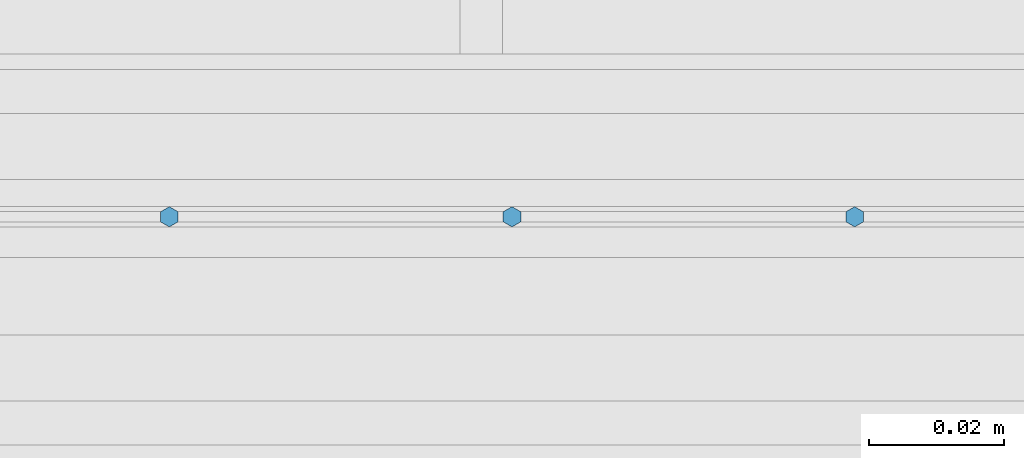
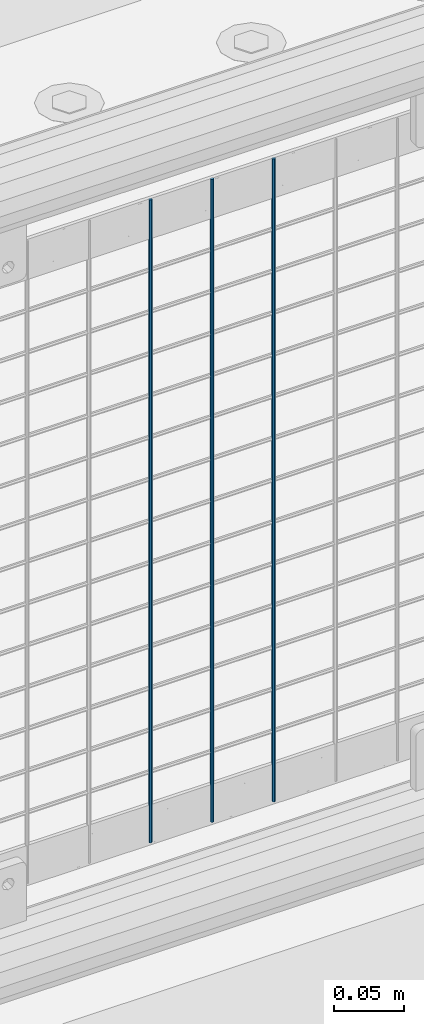
# One storey, part 87 of 242: 3 columns.
"""IFC2X3 building model written with IfcOpenShell, lengths in millimetres."""

from ifc_helpers import new_model, si_unit, frame, origin_with_axes, place, context, subcontext, project, spatial, faceted_brep, material, type_object, element, save


model = new_model("IFC2X3")

# Units and contexts
model_context = context("Model", 3, precision=1e-05, world=origin_with_axes())
body_context = subcontext(model_context, "Body", "Model", "MODEL_VIEW")
ifc_project = project(units=[si_unit("LENGTHUNIT", "METRE", prefix="MILLI"), si_unit("AREAUNIT", "SQUARE_METRE"), si_unit("VOLUMEUNIT", "CUBIC_METRE"), si_unit("MASSUNIT", "GRAM", prefix="KILO"), si_unit("TIMEUNIT", "SECOND"), si_unit("PLANEANGLEUNIT", "RADIAN"), si_unit("SOLIDANGLEUNIT", "STERADIAN"), si_unit("THERMODYNAMICTEMPERATUREUNIT", "DEGREE_CELSIUS"), si_unit("LUMINOUSINTENSITYUNIT", "LUMEN")], contexts=[model_context])

# Site, building, storey
site_placement = place(None, origin_with_axes())
site = spatial("IfcSite", under=ifc_project, at=site_placement, CompositionType="ELEMENT")
building_placement = place(site_placement, origin_with_axes())
building = spatial("IfcBuilding", under=site, at=building_placement, Name="Standard", CompositionType="ELEMENT")
storey_placement = place(building_placement, origin_with_axes())
storey = spatial("IfcBuildingStorey", under=building, at=storey_placement, Name="Undefined", CompositionType="ELEMENT", Elevation=0.0)

# Columns
ifc_material = material(Name="Misc_Undefined")
column_type = type_object("IfcColumnType", Name="D3", PredefinedType="NOTDEFINED")
for number, where, z_axis, x_axis in (
    (1, (-31341.484, -19329.5, 353.02), (-1.0, 0.0, 0.0), (0.0, 0.0, 1.0)),
    (2, (-31392.277, -19329.5, 353.02), (-1.0, 0.0, 0.0), (0.0, 0.0, 1.0)),
    (3, (-31443.07, -19329.5, 353.02), (-1.0, 0.0, 0.0), (0.0, 0.0, 1.0)),
):
    element("IfcColumn", number, at=place(storey_placement, frame(where, z_axis=z_axis, x_axis=x_axis)), inside=storey, type_object=column_type, material=ifc_material, ObjectType="D3", context=body_context, shape_type="Brep", body=[
        faceted_brep([(0.0, -1.50000000000364, 0.0), (-3.63797880709171e-12, -0.750000000003638, -1.29903810567669), (560.0, -0.75, -1.29903810567703), (560.0, -1.5, 0.0), (0.0, 0.749999999996362, -1.29903810567669), (560.0, 0.75, -1.29903810567703), (-3.63797880709171e-12, 1.49999999999636, 0.0), (560.0, 1.5, 0.0), (0.0, 0.749999999996362, 1.29903810567669), (560.0, 0.75, 1.29903810567703), (-3.63797880709171e-12, -0.750000000003638, 1.29903810567669), (560.0, -0.75, 1.29903810567703)], [[[0, 1, 2, 3]], [[1, 4, 5, 2]], [[4, 6, 7, 5]], [[6, 8, 9, 7]], [[8, 10, 11, 9]], [[10, 0, 3, 11]], [[5, 7, 9, 11, 3, 2]], [[10, 8, 6, 4, 1, 0]]]),
    ])

save(model, "model.ifc")
